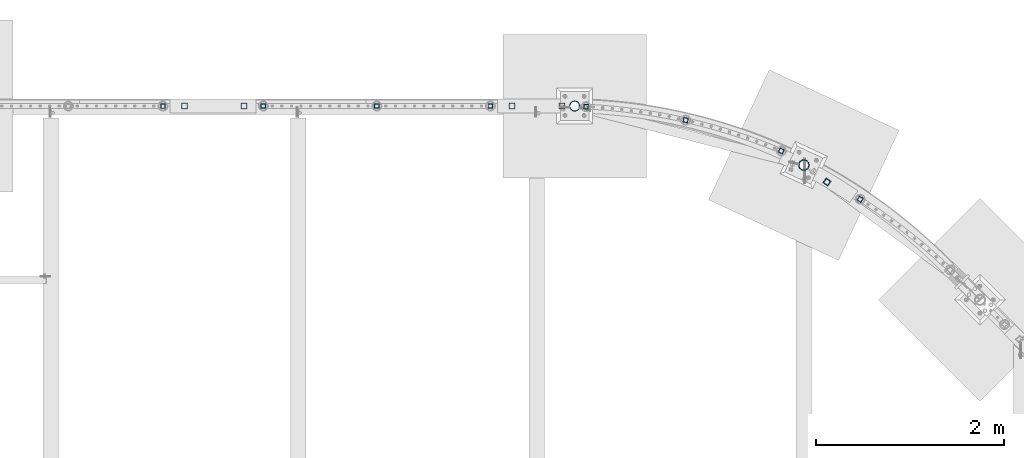
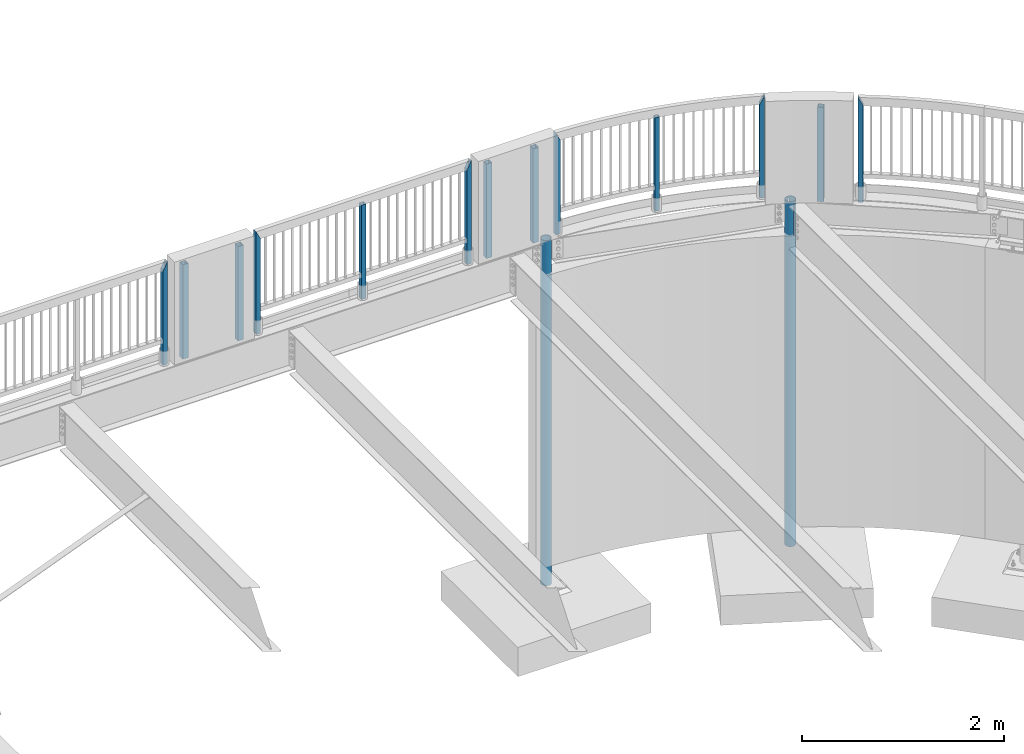
# One storey, part 130 of 975: 15 columns.
"""IFC2X3 building model written with IfcOpenShell, lengths in millimetres."""

from ifc_helpers import new_model, si_unit, frame, origin_with_axes, place, context, subcontext, project, spatial, faceted_brep, material, type_object, element, save


model = new_model("IFC2X3")

# Units and contexts
model_context = context("Model", 3, precision=1e-05, world=origin_with_axes())
body_context = subcontext(model_context, "Body", "Model", "MODEL_VIEW")
ifc_project = project(units=[si_unit("LENGTHUNIT", "METRE", prefix="MILLI"), si_unit("AREAUNIT", "SQUARE_METRE"), si_unit("VOLUMEUNIT", "CUBIC_METRE"), si_unit("MASSUNIT", "GRAM", prefix="KILO"), si_unit("TIMEUNIT", "SECOND"), si_unit("PLANEANGLEUNIT", "RADIAN"), si_unit("SOLIDANGLEUNIT", "STERADIAN"), si_unit("THERMODYNAMICTEMPERATUREUNIT", "DEGREE_CELSIUS"), si_unit("LUMINOUSINTENSITYUNIT", "LUMEN")], contexts=[model_context])

# Site, building, storey
site_placement = place(None, origin_with_axes())
site = spatial("IfcSite", under=ifc_project, at=site_placement, CompositionType="ELEMENT")
building_placement = place(site_placement, origin_with_axes())
building = spatial("IfcBuilding", under=site, at=building_placement, Name="Undefined", CompositionType="ELEMENT")
storey_placement = place(building_placement, origin_with_axes())
storey = spatial("IfcBuildingStorey", under=building, at=storey_placement, Name="Undefined", CompositionType="ELEMENT", Elevation=0.0)

# Columns
ifc_material_1 = material()
column_type_1 = type_object("IfcColumnType", Name="HSS2X2X.188_TUBES", PredefinedType="NOTDEFINED")
column_1_placement = place(storey_placement, frame((19457.8232733573, 28972.1749064253, 3911.60001178547), z_axis=(-0.845549851106994, 0.533896478067557, -5.33896582055605e-10), x_axis=(0.0, 0.0, 1.0)))
element("IfcColumn", 1, at=column_1_placement, inside=storey, type_object=column_type_1, material=ifc_material_1, Name="HANDRAIL", ObjectType="HSS2X2X.188_TUBES", context=body_context, shape_type="Brep", body=[
    faceted_brep([(0.0, 20.6374999999753, -20.6375000000298), (0.0, -20.6375000000153, -20.6375000000153), (1177.92497225151, -20.6375000000007, -20.6374999999875), (1177.92497102682, 20.6375000000371, -20.6374999999944), (0.0, -20.6374999999825, 20.6375000000335), (1260.47497075396, -20.6375000000335, 20.6375000000207), (0.0, 20.6375000000116, 20.6375000000189), (1260.47497199207, 20.6375000000007, 20.6375000000132), (0.0, 25.3999999999724, -25.4000000000342), (0.0, 25.400000000016, 25.4000000000196), (1269.99997196214, 25.4000000000015, 25.4000000000135), (1168.40000063294, 25.3999999999724, -25.4000000000342), (0.0, -25.399999999976, 25.4000000000378), (1269.99994272909, -25.3999999999614, 25.3999999999912), (0.0, -25.400000000016, -25.4000000000196), (1168.39999998263, -25.400000000016, -25.4000000000196)], [[[0, 1, 2, 3]], [[1, 4, 5, 2]], [[4, 6, 7, 5]], [[6, 0, 3, 7]], [[8, 9, 10, 11]], [[9, 12, 13, 10]], [[12, 14, 15, 13]], [[14, 8, 11, 15]], [[13, 15, 11, 10], [5, 7, 3, 2]], [[14, 12, 9, 8], [6, 4, 1, 0]]]),
])
column_2_placement = place(storey_placement, frame((17603.3055823473, 29812.5581130637, 3946.52501178547), z_axis=(-0.975657645912857, 0.219299242980415, -2.19299181480892e-10), x_axis=(0.0, 0.0, 1.0)))
element("IfcColumn", 2, at=column_2_placement, inside=storey, type_object=column_type_1, material=ifc_material_1, Name="HANDRAIL", ObjectType="HSS2X2X.188_TUBES", context=body_context, shape_type="Brep", body=[
    faceted_brep([(0.0, 20.6374999999753, -20.6375000000298), (0.0, -20.6375000000153, -20.6375000000153), (1133.47498819963, -20.6374999995132, -20.6374999998079), (1133.47498823965, 20.6375000004919, -20.6374999998552), (0.0, -20.6374999999825, 20.6375000000335), (1133.47498818942, -20.6374999995242, 20.6375000001026), (0.0, 20.6375000000116, 20.6375000000189), (1133.47498822943, 20.6375000004846, 20.6375000000626), (0.0, 25.3999999999724, -25.4000000000342), (0.0, 25.400000000016, 25.4000000000196), (1133.47498823287, 25.4000000004817, 25.4000000000487), (1133.47498824544, 25.4000000004926, -25.3999999998487), (0.0, -25.399999999976, 25.4000000000378), (1133.47498818362, -25.3999999995285, 25.4000000000997), (0.0, -25.400000000016, -25.4000000000196), (1133.47498819619, -25.399999999514, -25.3999999997941)], [[[0, 1, 2, 3]], [[1, 4, 5, 2]], [[4, 6, 7, 5]], [[6, 0, 3, 7]], [[8, 9, 10, 11]], [[9, 12, 13, 10]], [[12, 14, 15, 13]], [[14, 8, 11, 15]], [[13, 15, 11, 10], [5, 7, 3, 2]], [[14, 12, 9, 8], [6, 4, 1, 0]]]),
])
column_3_placement = place(storey_placement, frame((16544.9083073609, 29956.0420044469, 3946.52501178547), z_axis=(-0.999116847429244, 0.0420181530180525, -4.20182004745584e-11), x_axis=(0.0, 0.0, 1.0)))
element("IfcColumn", 3, at=column_3_placement, inside=storey, type_object=column_type_1, material=ifc_material_1, Name="HANDRAIL", ObjectType="HSS2X2X.188_TUBES", context=body_context, shape_type="Brep", body=[
    faceted_brep([(0.0, -25.400000000016, -25.4000000000196), (0.0, 25.3999999999724, -25.4000000000342), (1133.47498824544, 25.4000000004926, -25.3999999998487), (1133.47498819619, -25.399999999514, -25.3999999997941), (0.0, -25.399999999976, 25.4000000000378), (1235.07498821454, -25.3999999994921, 25.4000000000142), (0.0, 25.400000000016, 25.4000000000196), (1235.07498821454, 25.4000000005362, 25.4000000000615), (0.0, 20.6375000000116, 20.6375000000189), (0.0, -20.6374999999825, 20.6375000000335), (0.0, -20.6375000000153, -20.6375000000153), (0.0, 20.6374999999753, -20.6375000000298), (1225.55229408811, -20.6374999994878, 20.6375000000171), (1143.00022674645, -20.6374999994878, -20.637500000008), (1143.00022678779, 20.6375000005355, -20.6374999999716), (1225.55229412945, 20.6375000005355, 20.6375000000535)], [[[0, 1, 2, 3]], [[4, 0, 3, 5]], [[6, 4, 5, 7]], [[1, 6, 7, 2]], [[0, 4, 6, 1], [8, 9, 10, 11]], [[10, 9, 12, 13]], [[11, 10, 13, 14]], [[8, 11, 14, 15]], [[9, 8, 15, 12]], [[2, 7, 5, 3], [14, 13, 12, 15]]]),
])
column_4_placement = place(storey_placement, frame((18619.8058145146, 29485.1956485148, 3946.52501178547), z_axis=(-0.919935734123021, 0.392069184052431, -3.92069523513783e-10), x_axis=(0.0, 0.0, 1.0)))
element("IfcColumn", 4, at=column_4_placement, inside=storey, type_object=column_type_1, material=ifc_material_1, Name="HANDRAIL", ObjectType="HSS2X2X.188_TUBES", context=body_context, shape_type="Brep", body=[
    faceted_brep([(0.0, -25.400000000016, -25.4000000000196), (0.0, 25.3999999999724, -25.4000000000342), (1235.07498818869, 25.4000000000233, -25.4000000000415), (1235.07498820807, -25.4000000000397, -25.4000000000597), (0.0, -25.399999999976, 25.4000000000378), (1133.47498818362, -25.3999999995285, 25.4000000000997), (0.0, 25.400000000016, 25.4000000000196), (1133.47498823287, 25.4000000004817, 25.4000000000487), (0.0, 20.6375000000116, 20.6375000000189), (0.0, -20.6374999999825, 20.6375000000335), (0.0, -20.6375000000153, -20.6375000000153), (0.0, 20.6374999999753, -20.6375000000298), (1225.54998821705, -20.6375000000317, -20.6375000000407), (1225.5499881889, 20.6375000000189, -20.6375000000335), (1142.99998829488, 20.6375000000335, 20.637500000048), (1142.9999881907, -20.6375000000262, 20.6375000000335)], [[[0, 1, 2, 3]], [[4, 0, 3, 5]], [[6, 4, 5, 7]], [[1, 6, 7, 2]], [[0, 4, 6, 1], [8, 9, 10, 11]], [[11, 10, 12, 13]], [[8, 11, 13, 14]], [[9, 8, 14, 15]], [[10, 9, 15, 12]], [[7, 5, 3, 2], [14, 13, 12, 15]]]),
])
column_5_placement = place(storey_placement, frame((14322.4236175546, 29962.8586567184, 3937.0), z_axis=(1.0, 0.0, 0.0), x_axis=(0.0, 0.0, 1.0)))
element("IfcColumn", 5, at=column_5_placement, inside=storey, type_object=column_type_1, material=ifc_material_1, Name="HANDRAIL", ObjectType="HSS2X2X.188_TUBES", context=body_context, shape_type="Brep", body=[
    faceted_brep([(0.0, 20.6374999999753, -20.6375000000298), (0.0, -20.6375000000153, -20.6375000000153), (1142.99990218039, -20.6375000000007, -20.6374999992786), (1142.99990218039, 20.6375000000007, -20.6374999992786), (0.0, -20.6374999999825, 20.6375000000335), (1142.99992925681, -20.6375000000007, 20.637500000732), (0.0, 20.6375000000116, 20.6375000000189), (1142.99992925681, 20.6375000000007, 20.637500000732), (0.0, 25.3999999999724, -25.4000000000342), (0.0, 25.400000000016, 25.4000000000196), (1142.99993238101, 25.4000000000015, 25.4000000007327), (1142.99989905619, 25.4000000000015, -25.3999999992811), (0.0, -25.399999999976, 25.4000000000378), (1142.99993238101, -25.4000000000015, 25.4000000007327), (0.0, -25.400000000016, -25.4000000000196), (1142.99989905619, -25.4000000000015, -25.3999999992811)], [[[0, 1, 2, 3]], [[1, 4, 5, 2]], [[4, 6, 7, 5]], [[6, 0, 3, 7]], [[8, 9, 10, 11]], [[9, 12, 13, 10]], [[12, 14, 15, 13]], [[14, 8, 11, 15]], [[13, 15, 11, 10], [5, 7, 3, 2]], [[14, 12, 9, 8], [6, 4, 1, 0]]]),
])
column_6_placement = place(storey_placement, frame((15528.9293418726, 29962.8155335778, 3936.99988078704), z_axis=(1.0, 0.0, 0.0), x_axis=(0.0, 0.0, 1.0)))
element("IfcColumn", 6, at=column_6_placement, inside=storey, type_object=column_type_1, material=ifc_material_1, Name="HANDRAIL", ObjectType="HSS2X2X.188_TUBES", context=body_context, shape_type="Brep", body=[
    faceted_brep([(0.0, 20.6374999999753, -20.6375000000298), (0.0, -20.6375000000153, -20.6375000000153), (1152.52497983932, -20.6374999999462, -20.6374999999525), (1152.52900291014, 20.6374999999462, -20.6374999999489), (0.0, -20.6374999999825, 20.6375000000335), (1235.07090617935, -20.6375000000007, 20.6374999994514), (0.0, 20.6375000000116, 20.6375000000189), (1235.07497982248, 20.6374999999534, 20.6374999999471), (0.0, 25.3999999999724, -25.4000000000342), (0.0, 25.400000000016, 25.4000000000196), (1244.59997982054, 25.399999999936, 25.3999999999351), (1143.00499212253, 25.4000000000015, -25.4000000005071), (0.0, -25.399999999976, 25.4000000000378), (1244.59496625419, -25.4000000000015, 25.3999999994476), (0.0, -25.400000000016, -25.4000000000196), (1143.0, -25.4000000000106, -25.4000000000451)], [[[0, 1, 2, 3]], [[1, 4, 5, 2]], [[4, 6, 7, 5]], [[6, 0, 3, 7]], [[8, 9, 10, 11]], [[9, 12, 13, 10]], [[12, 14, 15, 13]], [[14, 8, 11, 15]], [[13, 15, 11, 10], [5, 7, 3, 2]], [[14, 12, 9, 8], [6, 4, 1, 0]]]),
])
column_7_placement = place(storey_placement, frame((13115.9195980836, 29962.9345599568, 3937.00001177477), z_axis=(1.0, 0.0, 0.0), x_axis=(0.0, 0.0, 1.0)))
element("IfcColumn", 7, at=column_7_placement, inside=storey, type_object=column_type_1, material=ifc_material_1, Name="HANDRAIL", ObjectType="HSS2X2X.188_TUBES", context=body_context, shape_type="Brep", body=[
    faceted_brep([(0.0, 20.6374999999753, -20.6375000000298), (0.0, -20.6375000000153, -20.6375000000153), (1235.074979717, -20.6374999999462, -20.6374999999462), (1235.07091767483, 20.6374999999871, -20.6375000000007), (0.0, -20.6374999999825, 20.6375000000335), (1152.52905859553, -20.6375000000121, 20.6375000000007), (0.0, 20.6375000000116, 20.6375000000189), (1152.52497980387, 20.6374999999534, 20.6374999999534), (0.0, 25.3999999999724, -25.4000000000342), (0.0, 25.400000000016, 25.4000000000196), (1143.0, 25.4000000000051, 25.4000000000378), (1244.59497833782, 25.3999999999869, -25.4000000000015), (0.0, -25.399999999976, 25.4000000000378), (1143.00499793254, -25.4000000000121, 25.4000000000015), (0.0, -25.400000000016, -25.4000000000196), (1244.59997970698, -25.399999999936, -25.399999999936)], [[[0, 1, 2, 3]], [[1, 4, 5, 2]], [[4, 6, 7, 5]], [[6, 0, 3, 7]], [[8, 9, 10, 11]], [[9, 12, 13, 10]], [[12, 14, 15, 13]], [[14, 8, 11, 15]], [[13, 15, 11, 10], [5, 7, 3, 2]], [[14, 12, 9, 8], [6, 4, 1, 0]]]),
])
column_8_placement = place(storey_placement, frame((12049.1279623652, 29962.0256740006, 3936.99172642828), z_axis=(1.0, 0.0, 0.0), x_axis=(0.0, 0.0, 1.0)))
element("IfcColumn", 8, at=column_8_placement, inside=storey, type_object=column_type_1, material=ifc_material_1, Name="HANDRAIL", ObjectType="HSS2X2X.188_TUBES", context=body_context, shape_type="Brep", body=[
    faceted_brep([(0.0, 20.6374999999753, -20.6375000000298), (0.0, -20.6375000000153, -20.6375000000153), (1152.52497983932, -20.6374999999462, -20.6374999999525), (1152.53185231482, 20.6375000000007, -20.6375000005119), (0.0, -20.6374999999825, 20.6375000000335), (1235.06810254331, -20.6375000000007, 20.6374999994514), (0.0, 20.6375000000116, 20.6375000000189), (1235.07497982248, 20.6374999999534, 20.6374999999471), (0.0, 25.3999999999724, -25.4000000000342), (0.0, 25.400000000016, 25.4000000000196), (1244.59997982054, 25.399999999936, 25.3999999999351), (1143.00843882692, 25.4000000000015, -25.4000000005071), (0.0, -25.399999999976, 25.4000000000378), (1244.59151603121, -25.4000000000015, 25.3999999994467), (0.0, -25.400000000016, -25.4000000000196), (1143.0, -25.4000000000106, -25.4000000000451)], [[[0, 1, 2, 3]], [[1, 4, 5, 2]], [[4, 6, 7, 5]], [[6, 0, 3, 7]], [[8, 9, 10, 11]], [[9, 12, 13, 10]], [[12, 14, 15, 13]], [[14, 8, 11, 15]], [[13, 15, 11, 10], [5, 7, 3, 2]], [[14, 12, 9, 8], [6, 4, 1, 0]]]),
])
column_type_2 = type_object("IfcColumnType", Name="HSS2-1/2X2-1/2X1/4", PredefinedType="NOTDEFINED")
for number, where, z_axis, x_axis in (
    (9, (12909.1017767645, 29962.4893275477, 3937.0), (0.0, 1.0, 0.0), (0.0, 0.0, 1.0)),
    (10, (12277.2767760911, 29962.4913745652, 3937.0), (0.0, 1.0, 0.0), (0.0, 0.0, 1.0)),
):
    element("IfcColumn", number, at=place(storey_placement, frame(where, z_axis=z_axis, x_axis=x_axis)), inside=storey, type_object=column_type_2, material=ifc_material_1, ObjectType="HSS2-1/2X2-1/2X1/4", context=body_context, shape_type="Brep", body=[
        faceted_brep([(0.0, 25.3999999999724, -25.4000000000342), (0.0, -25.400000000016, -25.4000000000196), (1143.0, -25.4000000000106, -25.4000000000451), (1143.0, 25.4000000000433, -25.4000000000087), (0.0, -25.399999999976, 25.4000000000378), (1143.0, -25.4000000000451, 25.4000000000087), (0.0, 25.400000000016, 25.4000000000196), (1143.0, 25.4000000000051, 25.4000000000378), (-5.45696821063757e-11, 31.7499999999909, -31.75000000002), (0.0, 31.7500000000127, 31.7500000000582), (1143.0, 31.7500000000127, 31.7500000000582), (1143.0, 31.7500000000546, -31.7500000000146), (0.0, -31.7500000000564, 31.7500000000073), (1143.0, -31.7500000000564, 31.7500000000073), (0.0, -31.7500000000146, -31.7500000000582), (1143.0, -31.7500000000146, -31.7500000000582)], [[[0, 1, 2, 3]], [[1, 4, 5, 2]], [[4, 6, 7, 5]], [[6, 0, 3, 7]], [[8, 9, 10, 11]], [[9, 12, 13, 10]], [[12, 14, 15, 13]], [[14, 8, 11, 15]], [[13, 15, 11, 10], [5, 7, 3, 2]], [[14, 12, 9, 8], [6, 4, 1, 0]]]),
    ])
column_9_placement = place(storey_placement, frame((19105.3033596217, 29155.1769476022, 3937.0), z_axis=(0.594099644036259, 0.804391455049089, 0.0), x_axis=(0.0, 0.0, 1.0)))
element("IfcColumn", 11, at=column_9_placement, inside=storey, type_object=column_type_2, material=ifc_material_1, ObjectType="HSS2-1/2X2-1/2X1/4", context=body_context, shape_type="Brep", body=[
    faceted_brep([(9.52500000004102, 25.4000000000499, -15.8186485830447), (9.52500000004102, 31.7500000000612, -15.8129278215492), (0.0, 31.7500000000612, -15.8129278215492), (0.0, 25.4000000000499, -15.8186485830447), (9.52500000004102, -31.7500000000443, -15.8701354364603), (9.52500000004102, -25.4000000000331, -15.8644146749721), (0.0, -25.4000000000331, -15.8644146749721), (0.0, -31.7500000000443, -15.8701354364603), (9.52500000000009, -31.7499573964276, 31.7027102934517), (9.52500000000055, 31.7500000000357, 31.7500000000655), (9.52500000000555, 25.4000000000262, 25.4000000000524), (9.52500000000555, -25.4000000000603, 25.4000000000233), (0.0, -31.7500000000146, -31.7500000000582), (-5.45696821063757e-11, 31.7499999999909, -31.75000000002), (1143.0, 31.7500000000546, -31.7500000000146), (1143.0, -31.7500000000146, -31.7500000000582), (0.0, 25.3999999999724, -25.4000000000342), (1143.0, 25.4000000000433, -25.4000000000087), (1143.0, 25.4000000000051, 25.4000000000378), (1143.0, -25.4000000000451, 25.4000000000087), (1143.0, -25.4000000000106, -25.4000000000451), (0.0, -25.400000000016, -25.4000000000196), (1143.0, -31.7500000000564, 31.7500000000073), (1143.0, 31.7500000000127, 31.7500000000582)], [[[0, 1, 2, 3]], [[4, 5, 6, 7]], [[8, 9, 1, 0, 10, 11, 5, 4]], [[12, 13, 14, 15]], [[3, 16, 17, 18, 10, 0]], [[18, 19, 11, 10]], [[19, 20, 21, 6, 5, 11]], [[16, 21, 20, 17]], [[22, 15, 14, 23], [19, 18, 17, 20]], [[7, 12, 15, 22, 8, 4]], [[21, 16, 3, 2, 13, 12, 7, 6]], [[23, 14, 13, 2, 1, 9]], [[22, 23, 9, 8]]]),
])
for number, where, z_axis, x_axis in (
    (12, (16290.9279716742, 29962.4742718859, 3936.99997614186), (0.0, 1.0, 0.0), (0.0, 0.0, 1.0)),
    (13, (15757.0767760774, 29962.4729611915, 3936.99997614186), (0.0, 1.0, 0.0), (0.0, 0.0, 1.0)),
):
    element("IfcColumn", number, at=place(storey_placement, frame(where, z_axis=z_axis, x_axis=x_axis)), inside=storey, type_object=column_type_2, material=ifc_material_1, ObjectType="HSS2-1/2X2-1/2X1/4", context=body_context, shape_type="Brep", body=[
        faceted_brep([(0.0, 25.3999999999724, -25.4000000000342), (0.0, -25.400000000016, -25.4000000000196), (1143.0, -25.4000000000106, -25.4000000000451), (1143.0, 25.4000000000433, -25.4000000000087), (0.0, -25.399999999976, 25.4000000000378), (1143.0, -25.4000000000451, 25.4000000000087), (0.0, 25.400000000016, 25.4000000000196), (1143.0, 25.4000000000051, 25.4000000000378), (-5.45696821063757e-11, 31.7499999999909, -31.75000000002), (0.0, 31.7500000000127, 31.7500000000582), (1143.0, 31.7500000000127, 31.7500000000582), (1143.0, 31.7500000000546, -31.7500000000146), (0.0, -31.7500000000564, 31.7500000000073), (1143.0, -31.7500000000564, 31.7500000000073), (0.0, -31.7500000000146, -31.7500000000582), (1143.0, -31.7500000000146, -31.7500000000582)], [[[0, 1, 2, 3]], [[1, 4, 5, 2]], [[4, 6, 7, 5]], [[6, 0, 3, 7]], [[8, 9, 10, 11]], [[9, 12, 13, 10]], [[12, 14, 15, 13]], [[14, 8, 11, 15]], [[13, 15, 11, 10], [5, 7, 3, 2]], [[14, 12, 9, 8], [6, 4, 1, 0]]]),
    ])
ifc_material_2 = material(Name="STEEL/A53")
column_type_3 = type_object("IfcColumnType", Name="PIPE4STD", PredefinedType="NOTDEFINED")
column_10_placement = place(storey_placement, frame((18859.5, 29335.3848385312, -266.7), z_axis=(0.422618261967726, 0.906307786930786, 0.0), x_axis=(0.0, 0.0, 1.0)))
element("IfcColumn", 14, at=column_10_placement, inside=storey, type_object=column_type_3, material=ifc_material_2, Name="COLUMN", ObjectType="PIPE4STD", context=body_context, shape_type="Brep", body=[
    faceted_brep([(4167.1875, -21.0391454364808, 52.6312829830422), (4167.1875, -18.5248582018694, 47.2393766117966), (3783.0125, -18.5248582018694, 47.2393766117966), (3783.0125, -21.0391454364808, 52.6312829830422), (3783.0125, -17.6603212285872, 54.3528799063351), (3783.0125, -15.8001007258417, 48.6277098895371), (3783.0125, -5.89118102863631, 50.1971285899999), (3783.0125, -8.50519926069774, 55.8029087753312), (4167.1875, -5.89118102863631, 50.1971285899999), (4167.1875, -8.50519926069774, 55.8029087753312), (4167.1875, -15.8001007258417, 48.6277098895371), (4167.1875, -17.6603212285872, 54.3528799063351), (19.0500000000025, -48.6277098894743, 15.8001007257917), (19.0500000000025, -41.3652007257897, 30.0535775067656), (4194.175, -41.3652007258652, 30.0535775067838), (4194.175, -48.6277098895507, 15.8001007257844), (19.0500000000025, -30.0535775067647, 41.3652007257915), (4194.175, -30.0535775068338, 41.3652007258279), (19.0500000000025, 0.0, 51.1301999999996), (19.0500000000025, 15.8001007257899, 48.6277098894752), (4194.175, 15.8001007257817, 48.6277098895516), (4194.175, -3.18323145620525e-11, 51.1302000000724), (19.0500000000025, 30.0535775067647, 41.3652007257915), (4194.175, 30.0535775067792, 41.3652007258715), (19.0500000000025, 41.3652007257897, 30.0535775067656), (4194.175, 41.3652007258252, 30.0535775068347), (19.0500000000025, 48.6277098894743, 15.8001007257917), (4194.175, 48.6277098895325, 15.8001007258426), (19.0500000000025, 51.1301999999996, 0.0), (4194.175, 51.1302000000696, 3.63797880709171e-11), (19.0500000000025, 48.6277098894743, -15.8001007257917), (4194.175, 48.6277098895507, -15.8001007257772), (19.0500000000025, 41.3652007257897, -30.0535775067656), (4194.175, 41.3652007258634, -30.0535775067765), (4194.175, 30.0535775068338, -41.3652007258279), (19.0500000000025, 30.0535775067647, -41.3652007257915), (3783.0125, 30.0535775068338, -41.3652007258279), (3783.0125, 34.6579705971753, -36.7608076354736), (4167.1875, 34.6579705971753, -36.7608076354736), (4167.1875, 30.0535775068338, -41.3652007258279), (19.0500000000025, 46.2353212285279, -33.5919271685161), (19.0500000000025, 54.3528799062678, -17.6603212285299), (4194.175, 54.3528799062697, -17.6603212285299), (4194.175, 46.235321228527, -33.5919271685161), (19.0500000000025, 57.1499999999996, 0.0), (4194.175, 57.1500000000015, 0.0), (19.0500000000025, 54.3528799062678, 17.6603212285299), (4194.175, 54.3528799062697, 17.6603212285299), (19.0500000000025, 46.2353212285279, 33.5919271685161), (4194.175, 46.235321228527, 33.5919271685161), (19.0500000000025, 33.5919271685152, 46.235321228527), (4194.175, 33.5919271685161, 46.235321228527), (19.0500000000025, 17.6603212285281, 54.3528799062697), (4194.175, 17.6603212285299, 54.3528799062697), (19.0500000000025, 0.0, 57.1500000000015), (4194.175, 0.0, 57.1500000000015), (4194.175, -17.6603212285299, 54.3528799062697), (19.0500000000025, -17.6603212285281, 54.3528799062697), (19.0500000000025, -33.5919271685152, 46.235321228527), (4194.175, -33.5919271685161, 46.235321228527), (19.0500000000025, -46.2353212285279, 33.5919271685161), (4194.175, -46.2353212285288, 33.5919271685161), (19.0500000000025, -54.3528799062678, 17.6603212285299), (4194.175, -54.3528799062678, 17.6603212285299), (19.0500000000025, -57.1499999999996, 0.0), (4194.175, -57.1499999999996, 0.0), (19.0500000000025, -54.3528799062678, -17.6603212285299), (4194.175, -54.3528799062678, -17.6603212285299), (19.0500000000025, -46.2353212285279, -33.5919271685161), (4194.175, -46.2353212285288, -33.5919271685161), (19.0500000000025, -33.5919271685152, -46.235321228527), (4194.175, -33.5919271685161, -46.235321228527), (19.0500000000025, -17.6603212285281, -54.3528799062697), (4194.175, -17.6603212285299, -54.3528799062697), (19.0500000000025, 0.0, -57.1500000000015), (4194.175, 0.0, -57.1500000000015), (19.0500000000025, 17.6603212285281, -54.3528799062697), (4194.175, 17.6603212285299, -54.3528799062697), (4194.175, 33.5919271685161, -46.235321228527), (19.0500000000025, 33.5919271685152, -46.235321228527), (3783.0125, 33.5919271685898, -46.235321228567), (3783.0125, 26.7004856004396, -49.7466860912537), (4167.1875, 26.7004856004396, -49.7466860912537), (4167.1875, 33.5919271685898, -46.235321228567), (4167.1875, 37.3319892528225, -42.4952591443289), (3783.0125, 37.3319892528225, -42.4952591443289), (3783.0125, 24.1861983658264, -44.3547797200008), (4167.1875, 24.1861983658264, -44.3547797200008), (19.0500000000025, 15.8001007257899, -48.6277098894752), (4194.175, 15.8001007258399, -48.6277098895298), (19.0500000000025, 0.0, -51.1301999999996), (4194.175, 3.00133251585066e-11, -51.1302000000724), (19.0500000000025, -15.8001007257899, -48.6277098894752), (4194.175, -15.8001007257799, -48.6277098895516), (19.0500000000025, -30.0535775067647, -41.3652007257915), (4194.175, -30.0535775067792, -41.3652007258643), (19.0500000000025, -41.3652007257897, -30.0535775067656), (4194.175, -41.365200725827, -30.0535775068274), (19.0500000000025, -48.6277098894743, -15.8001007257917), (4194.175, -48.6277098895325, -15.8001007258426), (19.0500000000025, -51.1301999999996, 0.0), (4194.175, -51.1302000000715, -2.91038304567337e-11), (4194.175, -15.8001007258417, 48.6277098895371), (19.0500000000025, -15.8001007257899, 48.6277098894752)], [[[0, 1, 2, 3]], [[4, 3, 2, 5, 6, 7]], [[7, 6, 8, 9]], [[9, 8, 10, 1, 0, 11]], [[12, 13, 14, 15]], [[13, 16, 17, 14]], [[18, 19, 20, 21]], [[19, 22, 23, 20]], [[22, 24, 25, 23]], [[24, 26, 27, 25]], [[26, 28, 29, 27]], [[28, 30, 31, 29]], [[30, 32, 33, 31]], [[34, 33, 32, 35, 36, 37, 38, 39]], [[40, 41, 42, 43]], [[41, 44, 45, 42]], [[44, 46, 47, 45]], [[46, 48, 49, 47]], [[48, 50, 51, 49]], [[50, 52, 53, 51]], [[52, 54, 55, 53]], [[56, 55, 54, 57, 4, 7, 9, 11]], [[3, 4, 57, 58, 59, 56, 11, 0]], [[58, 60, 61, 59]], [[60, 62, 63, 61]], [[62, 64, 65, 63]], [[64, 66, 67, 65]], [[66, 68, 69, 67]], [[68, 70, 71, 69]], [[70, 72, 73, 71]], [[72, 74, 75, 73]], [[74, 76, 77, 75]], [[78, 77, 76, 79, 80, 81, 82, 83]], [[80, 79, 40, 43, 78, 83, 84, 85]], [[37, 85, 84, 38]], [[36, 86, 81, 80, 85, 37]], [[87, 82, 81, 86]], [[38, 84, 83, 82, 87, 39]], [[86, 36, 35, 88, 89, 34, 39, 87]], [[88, 90, 91, 89]], [[90, 92, 93, 91]], [[92, 94, 95, 93]], [[94, 96, 97, 95]], [[96, 98, 99, 97]], [[98, 100, 101, 99]], [[69, 71, 73, 75, 77, 78, 43, 42, 45, 47, 49, 51, 53, 55, 56, 59, 61, 63, 65, 67], [14, 17, 102, 21, 20, 23, 25, 27, 29, 31, 33, 34, 89, 91, 93, 95, 97, 99, 101, 15]], [[100, 12, 15, 101]], [[62, 60, 58, 57, 54, 52, 50, 48, 46, 44, 41, 40, 79, 76, 74, 72, 70, 68, 66, 64], [98, 96, 94, 92, 90, 88, 35, 32, 30, 28, 26, 24, 22, 19, 18, 103, 16, 13, 12, 100]], [[102, 17, 16, 103, 5, 2, 1, 10]], [[5, 103, 18, 21, 102, 10, 8, 6]]]),
])
column_type_4 = type_object("IfcColumnType", Name="PIPE4XS", PredefinedType="NOTDEFINED")
column_11_placement = place(storey_placement, frame((16424.275, 29962.475, -266.7), z_axis=(0.0, 1.0, 0.0), x_axis=(0.0, 0.0, 1.0)))
element("IfcColumn", 15, at=column_11_placement, inside=storey, type_object=column_type_4, material=ifc_material_2, Name="COLUMN", ObjectType="PIPE4XS", context=body_context, shape_type="Brep", body=[
    faceted_brep([(19.050000000004, -48.5902000000006, 0.0), (19.050000000004, -46.2120263380839, 15.0151975600784), (4194.175, -46.2120263380839, 15.0151975600784), (4194.175, -48.5902000000006, 0.0), (19.050000000004, -39.3102975600777, 28.560602965943), (4194.175, -39.3102975600777, 28.560602965943), (19.050000000004, -28.560602965943, 39.3102975600777), (4194.175, -28.560602965943, 39.3102975600777), (19.050000000004, -15.0151975600784, 46.2120263380857), (4194.175, -15.0151975600784, 46.2120263380857), (19.050000000004, 0.0, 48.5901999999987), (4194.175, 0.0, 48.5901999999987), (19.050000000004, 15.0151975600784, 46.2120263380857), (4194.175, 15.0151975600784, 46.2120263380857), (19.050000000004, 28.560602965943, 39.3102975600777), (4194.175, 28.560602965943, 39.3102975600777), (19.050000000004, 39.3102975600777, 28.560602965943), (4194.175, 39.3102975600777, 28.560602965943), (19.050000000004, 46.2120263380857, 15.0151975600784), (4194.175, 46.2120263380857, 15.0151975600784), (19.050000000004, 48.5901999999987, 0.0), (4194.175, 48.5901999999987, 0.0), (19.050000000004, 46.2120263380857, -15.0151975600784), (4194.175, 46.2120263380857, -15.0151975600784), (19.050000000004, 39.3102975600777, -28.560602965943), (4194.175, 39.3102975600777, -28.560602965943), (19.050000000004, 28.560602965943, -39.3102975600777), (4194.175, 28.560602965943, -39.3102975600777), (19.050000000004, 15.0151975600784, -46.2120263380857), (4194.175, 15.0151975600784, -46.2120263380857), (19.050000000004, 0.0, -48.5901999999987), (4194.175, 0.0, -48.5901999999987), (19.050000000004, -15.0151975600784, -46.2120263380857), (4194.175, -15.0151975600784, -46.2120263380857), (19.050000000004, -28.560602965943, -39.3102975600777), (4194.175, -28.560602965943, -39.3102975600777), (19.050000000004, -39.3102975600777, -28.560602965943), (4194.175, -39.3102975600777, -28.560602965943), (19.050000000004, -46.2120263380839, -15.0151975600784), (4194.175, -46.2120263380839, -15.0151975600784), (19.0500000000025, -57.1499999999996, 0.0), (19.0500000000025, -54.3528799062678, -17.6603212285299), (4194.175, -54.3528799062678, -17.6603212285299), (4194.175, -57.1499999999996, 0.0), (19.0500000000025, -46.2353212285279, -33.5919271685161), (4194.175, -46.2353212285288, -33.5919271685161), (19.0500000000025, -33.5919271685152, -46.235321228527), (4194.175, -33.5919271685161, -46.235321228527), (19.0500000000025, -17.6603212285281, -54.3528799062697), (4194.175, -17.6603212285299, -54.3528799062697), (19.0500000000025, 0.0, -57.1500000000015), (4194.175, 0.0, -57.1500000000015), (19.0500000000025, 17.6603212285281, -54.3528799062697), (4194.175, 17.6603212285299, -54.3528799062697), (19.0500000000025, 33.5919271685152, -46.235321228527), (4194.175, 33.5919271685161, -46.235321228527), (19.0500000000025, 46.2353212285279, -33.5919271685161), (4194.175, 46.235321228527, -33.5919271685161), (19.0500000000025, 54.3528799062678, -17.6603212285299), (4194.175, 54.3528799062697, -17.6603212285299), (19.0500000000025, 57.1499999999996, 0.0), (4194.175, 57.1500000000015, 0.0), (19.0500000000025, 54.3528799062678, 17.6603212285299), (4194.175, 54.3528799062697, 17.6603212285299), (19.0500000000025, 46.2353212285279, 33.5919271685161), (4194.175, 46.235321228527, 33.5919271685161), (19.0500000000025, 33.5919271685152, 46.235321228527), (4194.175, 33.5919271685161, 46.235321228527), (19.0500000000025, 17.6603212285281, 54.3528799062697), (4194.175, 17.6603212285299, 54.3528799062697), (19.0500000000025, 0.0, 57.1500000000015), (4194.175, 0.0, 57.1500000000015), (19.0500000000025, -17.6603212285281, 54.3528799062697), (4194.175, -17.6603212285299, 54.3528799062697), (19.0500000000025, -33.5919271685152, 46.235321228527), (4194.175, -33.5919271685161, 46.235321228527), (19.0500000000025, -46.2353212285279, 33.5919271685161), (4194.175, -46.2353212285288, 33.5919271685161), (19.0500000000025, -54.3528799062678, 17.6603212285299), (4194.175, -54.3528799062678, 17.6603212285299)], [[[0, 1, 2, 3]], [[1, 4, 5, 2]], [[4, 6, 7, 5]], [[6, 8, 9, 7]], [[8, 10, 11, 9]], [[10, 12, 13, 11]], [[12, 14, 15, 13]], [[14, 16, 17, 15]], [[16, 18, 19, 17]], [[18, 20, 21, 19]], [[20, 22, 23, 21]], [[22, 24, 25, 23]], [[24, 26, 27, 25]], [[26, 28, 29, 27]], [[28, 30, 31, 29]], [[30, 32, 33, 31]], [[32, 34, 35, 33]], [[34, 36, 37, 35]], [[36, 38, 39, 37]], [[38, 0, 3, 39]], [[40, 41, 42, 43]], [[41, 44, 45, 42]], [[44, 46, 47, 45]], [[46, 48, 49, 47]], [[48, 50, 51, 49]], [[50, 52, 53, 51]], [[52, 54, 55, 53]], [[54, 56, 57, 55]], [[56, 58, 59, 57]], [[58, 60, 61, 59]], [[60, 62, 63, 61]], [[62, 64, 65, 63]], [[64, 66, 67, 65]], [[66, 68, 69, 67]], [[68, 70, 71, 69]], [[70, 72, 73, 71]], [[72, 74, 75, 73]], [[74, 76, 77, 75]], [[76, 78, 79, 77]], [[78, 40, 43, 79]], [[45, 47, 49, 51, 53, 55, 57, 59, 61, 63, 65, 67, 69, 71, 73, 75, 77, 79, 43, 42], [5, 7, 9, 11, 13, 15, 17, 19, 21, 23, 25, 27, 29, 31, 33, 35, 37, 39, 3, 2]], [[78, 76, 74, 72, 70, 68, 66, 64, 62, 60, 58, 56, 54, 52, 50, 48, 46, 44, 41, 40], [38, 36, 34, 32, 30, 28, 26, 24, 22, 20, 18, 16, 14, 12, 10, 8, 6, 4, 1, 0]]]),
])

save(model, "model.ifc")
